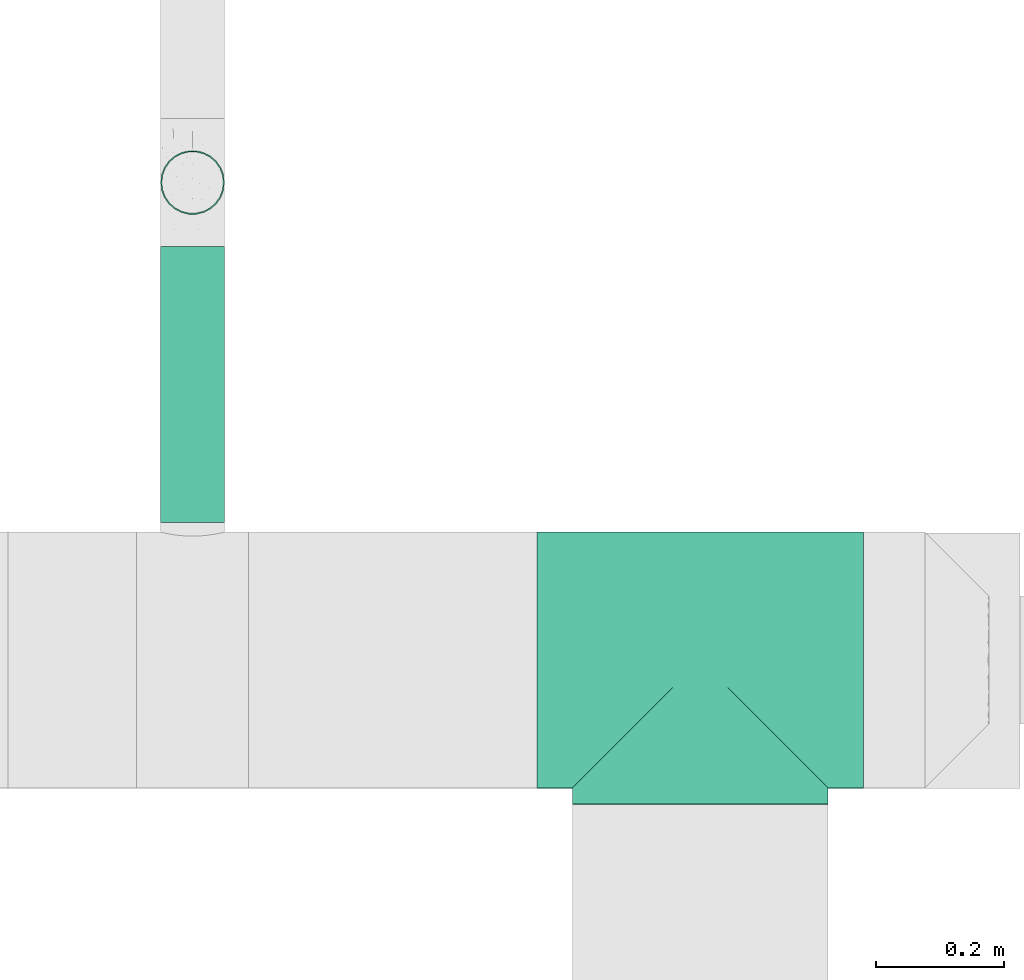
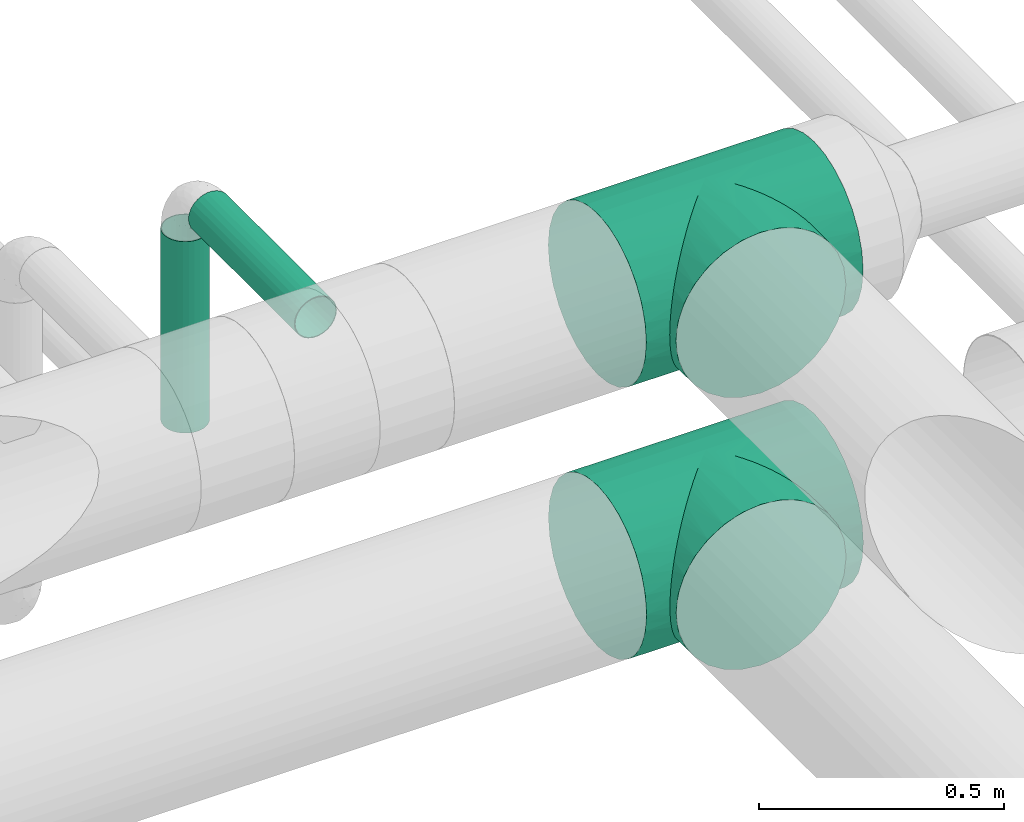
# One storey, part 82 of 91: 2 flow fittings, 2 flow segments.
"""IFC2X3 building model written with IfcOpenShell, lengths in millimetres."""

from ifc_helpers import new_model, entity, si_unit, converted_unit, derived_unit, direction, frame, origin_with_axes, origin_2d_with_axis, place, context, subcontext, project, spatial, hollow_circle, extrude, open_shell, surface_model, source, transform, mapped, material, layer, layer_set, layer_usage, type_object, element, save


model = new_model("IFC2X3")

# Units and contexts
model_context = context("Model", 3, precision=1e-05, world=origin_with_axes(), true_north=direction((0.0, 1.0)))
body_context = subcontext(model_context, "Body", "Model", "MODEL_VIEW")
ifc_project = project(units=[si_unit("AREAUNIT", "SQUARE_METRE"), si_unit("VOLUMEUNIT", "CUBIC_METRE", prefix="DECI"), si_unit("TIMEUNIT", "SECOND"), si_unit("THERMODYNAMICTEMPERATUREUNIT", "DEGREE_CELSIUS"), si_unit("PRESSUREUNIT", "PASCAL"), si_unit("MASSUNIT", "GRAM", prefix="KILO"), si_unit("LENGTHUNIT", "METRE", prefix="MILLI"), si_unit("POWERUNIT", "WATT"), si_unit("ELECTRICCURRENTUNIT", "AMPERE"), si_unit("ELECTRICVOLTAGEUNIT", "VOLT"), derived_unit("VOLUMETRICFLOWRATEUNIT", [(si_unit("VOLUMEUNIT", "CUBIC_METRE", prefix="DECI"), 1), (si_unit("TIMEUNIT", "SECOND"), -1)]), derived_unit("LINEARVELOCITYUNIT", [(si_unit("LENGTHUNIT", "METRE"), 1), (si_unit("TIMEUNIT", "SECOND"), -1)]), derived_unit("MASSDENSITYUNIT", [(si_unit("MASSUNIT", "GRAM", prefix="KILO"), 1), (si_unit("VOLUMEUNIT", "CUBIC_METRE"), -1)]), converted_unit("PLANEANGLEUNIT", "DEGREE", entity("IfcRatioMeasure", 0.01745), si_unit("PLANEANGLEUNIT", "RADIAN"), dimensions=[0, 0, 0, 0, 0, 0, 0])], contexts=[model_context])

# Site, building, storey
site_placement = place(None, origin_with_axes())
site = spatial("IfcSite", under=ifc_project, at=site_placement, CompositionType="ELEMENT")
building_placement = place(site_placement, origin_with_axes())
building = spatial("IfcBuilding", under=site, at=building_placement, Name="mc-building", CompositionType="ELEMENT")
storey_placement = place(building_placement, frame((0.0, 0.0, 8700.0), z_axis=(0.0, 0.0, 1.0), x_axis=(1.0, 0.0, 0.0)))
storey = spatial("IfcBuildingStorey", under=building, at=storey_placement, CompositionType="ELEMENT", Elevation=8700.0)

# Flow fittings
duct_fitting_type = type_object("IfcDuctFittingType", PredefinedType="JUNCTION")
shared_shape_1 = source(origin_with_axes(), body_context, "Body", "SurfaceModel", [
    surface_model("IfcShellBasedSurfaceModel", [(0.0, -225.0, -200.0), (44.50419, -225.0, -194.98559), (-44.50419, -225.0, -194.98559), (-194.98559, -225.0, 44.50419), (-86.77674, -225.0, -180.19378), (-180.19378, -225.0, -86.77674), (-156.36629, -225.0, -124.69796), (-124.69796, -225.0, -156.36629), (200.0, -225.0, 0.0), (194.98559, -225.0, 44.50419), (124.69796, -225.0, -156.36629), (86.77674, -225.0, -180.19378), (156.36629, -225.0, -124.69796), (180.19378, -225.0, -86.77674), (194.98559, -225.0, -44.50419), (-194.98559, -225.0, -44.50419), (-180.19378, -225.0, 86.77674), (-156.36629, -225.0, 124.69796), (-86.77674, -225.0, 180.19378), (-124.69796, -225.0, 156.36629), (-44.50419, -225.0, 194.98559), (0.0, -225.0, 200.0), (156.36629, -225.0, 124.69796), (180.19378, -225.0, 86.77674), (86.77674, -225.0, 180.19378), (44.50419, -225.0, 194.98559), (124.69796, -225.0, 156.36629), (-200.0, -225.0, 0.0), (0.0, -123.4504, 200.0), (-28.37474, -28.37474, 197.97696), (-42.47134, -42.47134, 195.43843), (0.0, 0.0, 200.0), (-14.20531, -14.20531, 199.49489), (-56.45592, -56.45592, 191.86643), (-70.28599, -70.28599, 187.24284), (-83.91465, -83.91465, 181.5443), (-110.34578, -110.34578, 166.8047), (-123.01465, -123.01465, 157.69399), (-135.21186, -135.21186, 147.36945), (-97.28852, -97.28852, 174.74251), (-191.21674, -191.21674, 58.61875), (-191.28763, -225.0, 55.07233), (-196.23918, -225.0, 33.37814), (-196.01972, -196.01972, 39.70228), (-197.50619, -197.50619, 29.87511), (-146.83339, -146.83339, 135.7938), (-157.75703, -157.75703, 122.93381), (-176.91349, -176.91349, 93.28243), (-168.28003, -225.0, 105.73735), (-187.58968, -225.0, 65.64047), (-184.77617, -184.77617, 76.53607), (-167.84094, -167.84094, 108.76313), (-197.4928, -225.0, 22.25209), (-198.99267, -198.99267, 20.04794), (-200.0, -200.0, 0.0), (-14.20531, -14.20531, -199.49489), (0.0, 0.0, -200.0), (0.0, -123.4504, -200.0), (-191.21674, -191.21674, -58.61875), (-187.58968, -225.0, -65.64047), (-191.28763, -225.0, -55.07233), (-184.77617, -184.77617, -76.53607), (-176.91349, -176.91349, -93.28243), (-146.83339, -146.83339, -135.7938), (-197.4928, -225.0, -22.25209), (-197.50619, -197.50619, -29.87511), (-196.23918, -225.0, -33.37814), (-167.84094, -167.84094, -108.76313), (-157.75703, -157.75703, -122.93381), (-196.01972, -196.01972, -39.70228), (-168.28003, -225.0, -105.73735), (-198.99267, -198.99267, -20.04794), (-135.21186, -135.21186, -147.36945), (-70.28599, -70.28599, -187.24284), (-56.45592, -56.45592, -191.86643), (-83.91465, -83.91465, -181.5443), (-28.37474, -28.37474, -197.97696), (-42.47134, -42.47134, -195.43843), (-123.01465, -123.01465, -157.69399), (-110.34578, -110.34578, -166.8047), (-97.28852, -97.28852, -174.74251), (0.0, -123.45037, -200.0), (28.37474, -28.37474, -197.97696), (42.47134, -42.47134, -195.43843), (14.20531, -14.20531, -199.49489), (56.45592, -56.45592, -191.86643), (70.28599, -70.28599, -187.24284), (83.91465, -83.91465, -181.5443), (110.34578, -110.34578, -166.8047), (123.01465, -123.01465, -157.69399), (135.21186, -135.21186, -147.36945), (97.28852, -97.28852, -174.74251), (191.21674, -191.21674, -58.61875), (191.28763, -225.0, -55.07233), (196.23918, -225.0, -33.37814), (196.01972, -196.01972, -39.70228), (197.50619, -197.50619, -29.87511), (146.83339, -146.83339, -135.7938), (157.75703, -157.75703, -122.93381), (176.91349, -176.91349, -93.28243), (168.28003, -225.0, -105.73735), (187.58968, -225.0, -65.64047), (184.77617, -184.77617, -76.53607), (167.84094, -167.84094, -108.76313), (197.4928, -225.0, -22.25209), (198.99267, -198.99267, -20.04794), (200.0, -200.0, 0.0), (14.20531, -14.20531, 199.49489), (191.21674, -191.21674, 58.61875), (187.58968, -225.0, 65.64047), (191.28763, -225.0, 55.07233), (184.77617, -184.77617, 76.53607), (176.91349, -176.91349, 93.28243), (146.83339, -146.83339, 135.7938), (197.4928, -225.0, 22.25209), (197.50619, -197.50619, 29.87511), (196.23918, -225.0, 33.37814), (167.84094, -167.84094, 108.76313), (157.75703, -157.75703, 122.93381), (196.01972, -196.01972, 39.70228), (168.28003, -225.0, 105.73735), (198.99267, -198.99267, 20.04794), (135.21186, -135.21186, 147.36945), (70.28599, -70.28599, 187.24284), (56.45592, -56.45592, 191.86643), (83.91465, -83.91465, 181.5443), (28.37474, -28.37474, 197.97696), (42.47134, -42.47134, 195.43843), (123.01465, -123.01465, 157.69399), (110.34578, -110.34578, 166.8047), (97.28852, -97.28852, 174.74251), (-255.0, 0.0, -200.0), (-255.0, -44.50419, -194.98559), (-255.0, 44.50419, -194.98559), (-255.0, 194.98559, 44.50419), (-255.0, 86.77674, -180.19378), (-255.0, 180.19378, -86.77674), (-255.0, 156.36629, -124.69796), (-255.0, 124.69796, -156.36629), (-255.0, -200.0, 0.0), (-255.0, -194.98559, 44.50419), (-255.0, -124.69796, -156.36629), (-255.0, -86.77674, -180.19378), (-255.0, -156.36629, -124.69796), (-255.0, -180.19378, -86.77674), (-255.0, -194.98559, -44.50419), (-255.0, 194.98559, -44.50419), (-255.0, 180.19378, 86.77674), (-255.0, 156.36629, 124.69796), (-255.0, 86.77674, 180.19378), (-255.0, 124.69796, 156.36629), (-255.0, 44.50419, 194.98559), (-255.0, 0.0, 200.0), (-255.0, -156.36629, 124.69796), (-255.0, -180.19378, 86.77674), (-255.0, -86.77674, 180.19378), (-255.0, -44.50419, 194.98559), (-255.0, -124.69796, 156.36629), (-255.0, 200.0, 0.0), (255.0, 180.19378, 86.77674), (255.0, 0.0, -200.0), (255.0, 44.50419, -194.98559), (255.0, 86.77674, -180.19378), (255.0, 200.0, 0.0), (255.0, 156.36629, -124.69796), (255.0, 180.19378, -86.77674), (255.0, 124.69796, -156.36629), (255.0, -156.36629, -124.69796), (255.0, -194.98559, 44.50419), (255.0, -86.77674, -180.19378), (255.0, -44.50419, -194.98559), (255.0, -124.69796, -156.36629), (255.0, -180.19378, -86.77674), (255.0, -194.98559, -44.50419), (255.0, -200.0, 0.0), (255.0, 194.98559, -44.50419), (255.0, 194.98559, 44.50419), (255.0, 156.36629, 124.69796), (255.0, 124.69796, 156.36629), (255.0, 86.77674, 180.19378), (255.0, 44.50419, 194.98559), (255.0, -156.36629, 124.69796), (255.0, -180.19378, 86.77674), (255.0, -124.69796, 156.36629), (255.0, -86.77674, 180.19378), (255.0, -44.50419, 194.98559), (255.0, 0.0, 200.0), (-123.45043, 0.0, -200.0), (-255.0, -187.58968, -65.64047), (-255.0, -197.4928, -22.25209), (123.4504, 0.0, -200.0), (255.0, -187.58968, -65.64047), (255.0, -197.4928, -22.25209), (-255.0, -187.58968, 65.64047), (-123.4504, 0.0, 200.0), (-255.0, -197.4928, 22.25209), (255.0, -197.4928, 22.25209), (255.0, -187.58968, 65.64047), (123.4504, 0.0, 200.0)], [open_shell([[[0, 1, 2]], [[2, 3, 4]], [[3, 5, 6]], [[6, 7, 3]], [[7, 4, 3]], [[2, 8, 9]], [[10, 8, 11]], [[2, 1, 11]], [[8, 12, 13]], [[13, 14, 8]], [[8, 10, 12]], [[11, 8, 2]], [[3, 15, 5]], [[2, 16, 3]], [[2, 17, 16]], [[18, 19, 17]], [[18, 2, 20]], [[18, 17, 2]], [[20, 2, 21]], [[22, 21, 23]], [[2, 9, 23]], [[24, 25, 21]], [[21, 26, 24]], [[22, 26, 21]], [[2, 23, 21]], [[27, 15, 3]], [[28, 29, 30]], [[31, 32, 28]], [[30, 33, 20]], [[34, 35, 18]], [[33, 34, 20]], [[30, 20, 28]], [[34, 18, 20]], [[21, 28, 20]], [[36, 19, 18]], [[37, 19, 36]], [[19, 37, 38]], [[36, 18, 39]], [[39, 18, 35]], [[40, 3, 41]], [[42, 43, 44]], [[45, 46, 17]], [[45, 17, 19]], [[47, 16, 48]], [[29, 28, 32]], [[40, 49, 50]], [[47, 48, 51]], [[52, 44, 53]], [[47, 50, 16]], [[46, 51, 17]], [[49, 16, 50]], [[48, 17, 51]], [[42, 3, 43]], [[53, 27, 52]], [[54, 27, 53]], [[40, 41, 49]], [[44, 52, 42]], [[43, 3, 40]], [[45, 19, 38]], [[55, 56, 57]], [[58, 59, 60]], [[61, 62, 5]], [[61, 5, 59]], [[6, 63, 7]], [[64, 65, 66]], [[67, 68, 6]], [[69, 15, 66]], [[63, 6, 68]], [[66, 65, 69]], [[67, 70, 62]], [[27, 54, 71]], [[67, 6, 70]], [[27, 71, 64]], [[71, 65, 64]], [[69, 58, 15]], [[15, 58, 60]], [[70, 5, 62]], [[61, 59, 58]], [[63, 72, 7]], [[73, 74, 2]], [[75, 73, 4]], [[0, 2, 57]], [[76, 57, 77]], [[57, 76, 55]], [[74, 77, 2]], [[7, 78, 79]], [[78, 7, 72]], [[7, 79, 4]], [[80, 4, 79]], [[80, 75, 4]], [[4, 73, 2]], [[2, 77, 57]], [[81, 82, 83]], [[56, 84, 81]], [[83, 85, 1]], [[86, 87, 11]], [[85, 86, 1]], [[83, 1, 81]], [[86, 11, 1]], [[0, 81, 1]], [[88, 10, 11]], [[89, 10, 88]], [[10, 89, 90]], [[88, 11, 91]], [[91, 11, 87]], [[92, 14, 93]], [[94, 95, 96]], [[97, 98, 12]], [[97, 12, 10]], [[99, 13, 100]], [[82, 81, 84]], [[92, 101, 102]], [[99, 100, 103]], [[104, 96, 105]], [[99, 102, 13]], [[98, 103, 12]], [[101, 13, 102]], [[100, 12, 103]], [[94, 14, 95]], [[105, 8, 104]], [[106, 8, 105]], [[92, 93, 101]], [[96, 104, 94]], [[95, 14, 92]], [[97, 10, 90]], [[107, 31, 28]], [[108, 109, 110]], [[111, 112, 23]], [[111, 23, 109]], [[22, 113, 26]], [[114, 115, 116]], [[117, 118, 22]], [[119, 9, 116]], [[113, 22, 118]], [[116, 115, 119]], [[117, 120, 112]], [[106, 121, 8]], [[117, 22, 120]], [[8, 121, 114]], [[121, 115, 114]], [[119, 108, 9]], [[9, 108, 110]], [[120, 23, 112]], [[111, 109, 108]], [[113, 122, 26]], [[123, 124, 25]], [[125, 123, 24]], [[21, 25, 28]], [[126, 28, 127]], [[28, 126, 107]], [[124, 127, 25]], [[26, 128, 129]], [[128, 26, 122]], [[26, 129, 24]], [[130, 24, 129]], [[130, 125, 24]], [[24, 123, 25]], [[25, 127, 28]], [[131, 132, 133]], [[133, 134, 135]], [[134, 136, 137]], [[137, 138, 134]], [[138, 135, 134]], [[133, 139, 140]], [[141, 139, 142]], [[133, 132, 142]], [[139, 143, 144]], [[144, 145, 139]], [[139, 141, 143]], [[142, 139, 133]], [[134, 146, 136]], [[133, 147, 134]], [[133, 148, 147]], [[149, 150, 148]], [[149, 133, 151]], [[149, 148, 133]], [[151, 133, 152]], [[153, 152, 154]], [[133, 140, 154]], [[155, 156, 152]], [[152, 157, 155]], [[153, 157, 152]], [[133, 154, 152]], [[158, 146, 134]], [[159, 160, 161]], [[162, 163, 161]], [[164, 165, 163]], [[163, 166, 164]], [[163, 162, 166]], [[167, 160, 168]], [[160, 169, 170]], [[160, 171, 169]], [[171, 160, 167]], [[167, 168, 172]], [[173, 172, 168]], [[173, 168, 174]], [[165, 175, 163]], [[163, 176, 159]], [[177, 160, 159]], [[177, 178, 179]], [[180, 160, 179]], [[160, 177, 179]], [[160, 180, 181]], [[181, 182, 160]], [[168, 160, 182]], [[181, 180, 183]], [[183, 180, 184]], [[185, 184, 180]], [[186, 185, 180]], [[161, 163, 159]], [[31, 186, 180]], [[31, 180, 151]], [[149, 180, 179]], [[152, 31, 151]], [[151, 180, 149]], [[179, 150, 149]], [[179, 178, 150]], [[147, 177, 159]], [[134, 159, 176]], [[158, 176, 163]], [[178, 148, 150]], [[178, 177, 148]], [[147, 148, 177]], [[159, 134, 147]], [[176, 158, 134]], [[163, 175, 146]], [[175, 165, 136]], [[137, 165, 164]], [[146, 158, 163]], [[136, 146, 175]], [[165, 137, 136]], [[164, 138, 137]], [[135, 166, 162]], [[133, 162, 161]], [[56, 161, 160]], [[138, 166, 135]], [[133, 56, 131]], [[133, 135, 162]], [[56, 133, 161]], [[166, 138, 164]], [[187, 76, 77]], [[56, 55, 187]], [[77, 74, 132]], [[73, 75, 142]], [[74, 73, 132]], [[77, 132, 187]], [[73, 142, 132]], [[131, 187, 132]], [[79, 141, 142]], [[78, 141, 79]], [[141, 78, 72]], [[79, 142, 80]], [[80, 142, 75]], [[63, 68, 143]], [[63, 143, 141]], [[67, 62, 144]], [[58, 188, 61]], [[76, 187, 55]], [[62, 61, 144]], [[68, 67, 143]], [[188, 144, 61]], [[144, 143, 67]], [[189, 145, 69]], [[71, 139, 189]], [[54, 139, 71]], [[58, 145, 188]], [[189, 69, 71]], [[69, 145, 58]], [[63, 141, 72]], [[190, 170, 83]], [[169, 86, 170]], [[89, 171, 90]], [[171, 89, 88]], [[91, 169, 88]], [[88, 169, 171]], [[91, 87, 169]], [[160, 170, 190]], [[84, 190, 82]], [[87, 86, 169]], [[85, 83, 170]], [[86, 85, 170]], [[190, 83, 82]], [[172, 103, 167]], [[173, 92, 191]], [[174, 106, 105]], [[102, 191, 92]], [[173, 192, 95]], [[95, 192, 105]], [[105, 192, 174]], [[95, 92, 173]], [[90, 171, 97]], [[98, 97, 167]], [[84, 56, 190]], [[102, 172, 191]], [[99, 103, 172]], [[102, 99, 172]], [[98, 167, 103]], [[97, 171, 167]], [[50, 47, 154]], [[50, 154, 193]], [[153, 45, 157]], [[51, 46, 153]], [[45, 153, 46]], [[32, 31, 194]], [[47, 51, 154]], [[54, 53, 139]], [[50, 193, 40]], [[139, 53, 195]], [[140, 195, 43]], [[43, 40, 140]], [[140, 40, 193]], [[51, 153, 154]], [[43, 195, 53]], [[45, 38, 157]], [[34, 33, 156]], [[35, 34, 155]], [[152, 156, 194]], [[29, 194, 30]], [[194, 29, 32]], [[33, 30, 156]], [[157, 37, 36]], [[37, 157, 38]], [[157, 36, 155]], [[39, 155, 36]], [[39, 35, 155]], [[155, 34, 156]], [[156, 30, 194]], [[106, 174, 121]], [[196, 168, 119]], [[121, 174, 196]], [[197, 182, 111]], [[108, 119, 168]], [[119, 121, 196]], [[182, 181, 117]], [[108, 168, 197]], [[108, 197, 111]], [[112, 111, 182]], [[118, 117, 181]], [[183, 122, 113]], [[118, 181, 113]], [[112, 182, 117]], [[126, 198, 107]], [[113, 181, 183]], [[183, 129, 128]], [[129, 183, 184]], [[183, 128, 122]], [[123, 184, 185]], [[125, 130, 184]], [[184, 130, 129]], [[186, 198, 185]], [[123, 125, 184]], [[124, 123, 185]], [[127, 185, 198]], [[31, 107, 198]], [[126, 127, 198]], [[124, 185, 127]]])]),
])
for number, where, z_axis, x_axis in (
    (1, (31866.56389, 10080.05037, 668.0), (0.0, 0.0, 1.0), (1.0, 0.0, 0.0)),
    (2, (31866.56389, 10080.96985, 1344.0), (0.0, 0.0, 1.0), (1.0, 0.0, 0.0)),
):
    element("IfcFlowFitting", number, at=place(storey_placement, frame(where, z_axis=z_axis, x_axis=x_axis)), inside=storey, type_object=duct_fitting_type, context=body_context, shape_type="MappedRepresentation", body=[
        mapped(shared_shape_1, transform((0.0, 0.0, 0.0), scale=1.0)),
    ])

# Flow segments
ifc_material = material(Name="FZ1")
ifc_layer = layer(ifc_material, 0.0)
ifc_layer_set = layer_set([ifc_layer], Name="FZ1")
ifc_layer_usage = layer_usage(ifc_layer_set, "AXIS1", "POSITIVE", 0.0)
duct_segment_type = type_object("IfcDuctSegmentType", PredefinedType="RIGIDSEGMENT")
shared_shape_2 = source(origin_with_axes(), body_context, "Body", "SweptSolid", [
    extrude(hollow_circle(Radius=50.0, WallThickness=2.0, at=origin_2d_with_axis()), frame((0.0, 0.0, 0.0), z_axis=(1.0, 0.0, 0.0), x_axis=(0.0, 1.0, 0.0)), (0.0, 0.0, 1.0), 476.0),
])
flow_segment_1_placement = place(storey_placement, frame((31073.17179, 10827.25695, 1244.0), z_axis=(0.0, 1.0, 0.0), x_axis=(0.0, 0.0, -1.0)))
element("IfcFlowSegment", 3, at=flow_segment_1_placement, inside=storey, type_object=duct_segment_type, material=ifc_layer_usage, context=body_context, shape_type="MappedRepresentation", body=[
    mapped(shared_shape_2, transform((0.0, 0.0, 0.0), scale=1.0)),
])
shared_shape_3 = source(origin_with_axes(), body_context, "Body", "SweptSolid", [
    extrude(hollow_circle(Radius=50.0, WallThickness=2.0, at=origin_2d_with_axis()), frame((0.0, 0.0, 0.0), z_axis=(1.0, 0.0, 0.0), x_axis=(0.0, 1.0, 0.0)), (0.0, 0.0, 1.0), 431.3),
])
flow_segment_2_placement = place(storey_placement, frame((31073.17179, 10295.96985, 1344.0), z_axis=(0.0, 0.0, 1.0), x_axis=(0.0, 1.0, 0.0)))
element("IfcFlowSegment", 4, at=flow_segment_2_placement, inside=storey, type_object=duct_segment_type, material=ifc_layer_usage, context=body_context, shape_type="MappedRepresentation", body=[
    mapped(shared_shape_3, transform((0.0, 0.0, 0.0), scale=1.0)),
])

save(model, "model.ifc")
